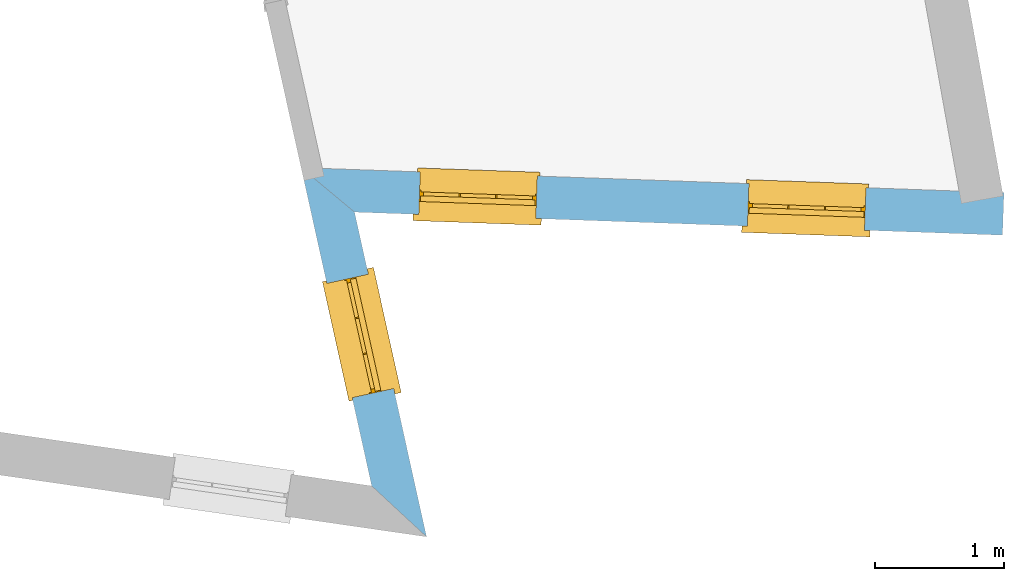
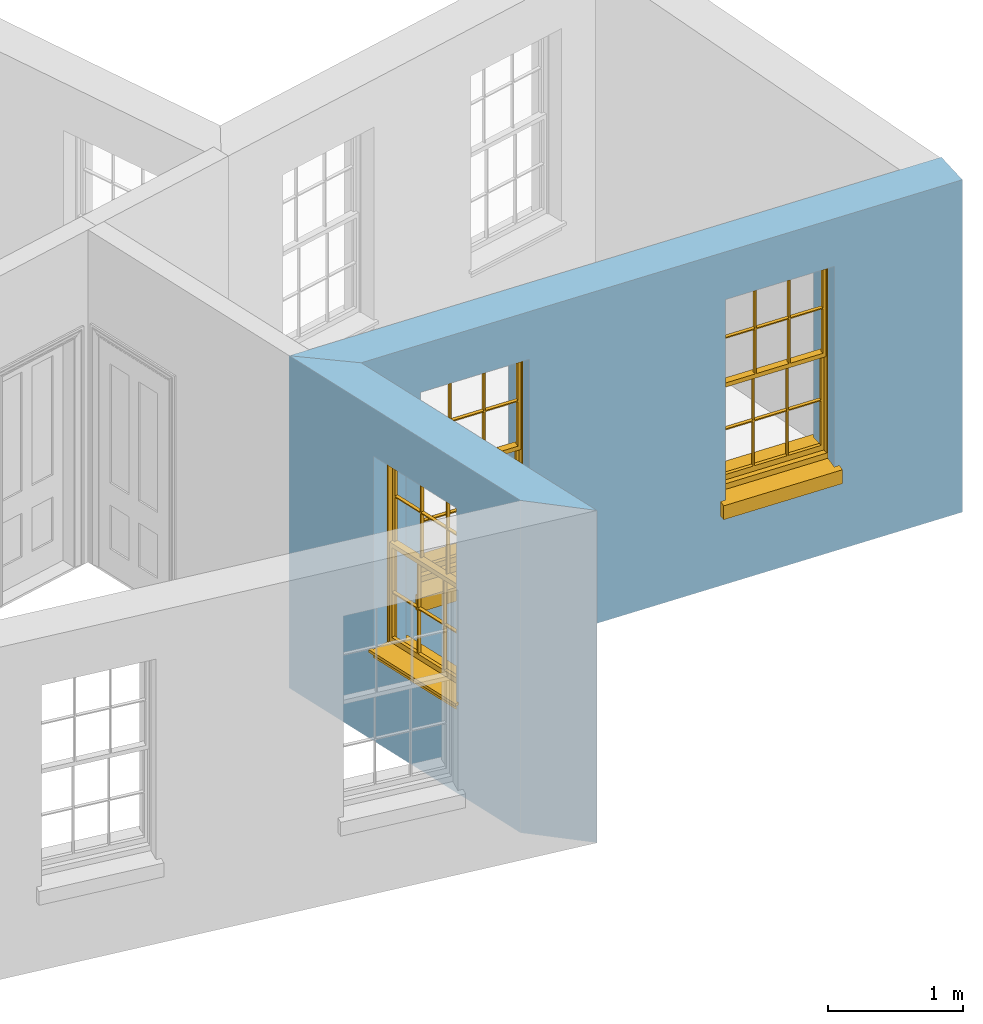
# One storey, part 6 of 10: 3 windows, 3 openings, plus 2 elements that do not belong to this part.
"""IFC2X3 building model written with IfcOpenShell, lengths in metres."""

from ifc_helpers import new_model, si_unit, frame, origin, place, context, subcontext, project, spatial, polyline, outline, extrude, faceted_brep, material, layer, layer_set, layer_usage, element, fill, save


model = new_model("IFC2X3")

# Units and contexts
model_context = context("Model", 3, world=origin())
body_context = subcontext(model_context, "Body", "Model", "MODEL_VIEW")
ifc_project = project(units=[si_unit("PLANEANGLEUNIT", "RADIAN"), si_unit("MASSUNIT", "GRAM", prefix="KILO"), si_unit("FORCEUNIT", "NEWTON", prefix="KILO"), si_unit("LENGTHUNIT", "METRE")], contexts=[model_context])

# Site, building, storey
site_placement = place(None, origin())
site = spatial("IfcSite", under=ifc_project, at=site_placement, CompositionType="ELEMENT")
building_placement = place(None, origin())
building = spatial("IfcBuilding", under=site, at=building_placement, Name="Building plot-16", CompositionType="ELEMENT")
storey_placement = place(None, frame((0.0, 0.0, 6.0)))
storey = spatial("IfcBuildingStorey", under=building, at=storey_placement, Name="Floor 1", CompositionType="ELEMENT", Elevation=6.0)

# Wall, opening, window
ifc_material = material(Name="Masonry")
ifc_layer = layer(ifc_material, 0.33, ventilated=False)
ifc_layer_set = layer_set([ifc_layer], Name="My Wall")
ifc_layer_usage = layer_usage(ifc_layer_set, "AXIS2", "NEGATIVE", 0.08)
wall_1_placement = place(storey_placement, origin())
wall_1 = element("IfcWallStandardCase", 1, at=wall_1_placement, inside=storey, material=ifc_layer_usage, Name="exterior", context=body_context, shape_type="SweptSolid", body=[
    extrude(outline(polyline([(97.1549084446968, 30.7413476988825), (97.5805288405461, 30.3463147311604), (97.0216212073761, 32.8666175367297), (96.607105896403, 33.2115739356083), (97.1549084446968, 30.7413476988825)])), origin(), (0.0, 0.0, 1.0), 3.0),
])
opening_1_placement = place(storey_placement, frame((0.0, 0.0, 0.75)))
opening_1 = element("IfcOpeningElement", 2, at=opening_1_placement, cuts=wall_1, Name="Opening", ObjectType="Opening", context=body_context, shape_type="SweptSolid", body=[
    extrude(outline(polyline([(97.3254209005413, 31.496682374684), (97.1284037496912, 32.3850990799923), (96.8062306587552, 32.3136533000138), (97.0032478096053, 31.4252365947054), (97.3254209005413, 31.496682374684)])), origin(), (0.0, 0.0, 1.0), 1.82),
])
window_1_placement = place(storey_placement, frame((97.0813503771049, 31.4425567837911, 0.75), z_axis=(0.0, 0.0, 1.0), x_axis=(-0.197017150850044, 0.888416705308341, 0.0)))
window_1 = element("IfcWindow", 3, at=window_1_placement, inside=storey, Name="circulation outside window", OverallHeight=1.82, OverallWidth=0.91, context=body_context, shape_type="Brep", held_by="IfcProductRepresentation", body=[
    faceted_brep([(0.033125, -0.105, 0.975209), (0.01, -0.105, 0.975209), (0.033125, -0.105, 1.376042), (0.876875, -0.105, 0.975209), (0.876875, -0.105, 1.376042), (0.9, -0.105, 0.975209), (0.876875, -0.105, 1.386042), (0.876875, -0.105, 1.786875), (0.9, -0.105, 1.81), (0.033125, -0.105, 1.786875), (0.033125, -0.105, 1.386042), (0.01, -0.105, 1.81), (0.876875, -0.135, 1.376042), (0.876875, -0.135, 0.975209), (0.9, -0.135, 0.937083), (0.033125, -0.135, 1.786875), (0.01, -0.135, 1.81), (0.033125, -0.135, 1.386042), (0.01, -0.135, 0.937083), (0.033125, -0.135, 0.975209), (0.033125, -0.135, 1.376042), (0.876875, -0.135, 1.786875), (0.876875, -0.135, 1.386042), (0.9, -0.135, 1.81), (0.033125, -0.105, 0.937083), (0.01, -0.105, 0.937083), (0.033125, -0.105, 0.53625), (0.876875, -0.105, 0.937083), (0.876875, -0.105, 0.53625), (0.9, -0.105, 0.937083), (0.876875, -0.105, 0.52625), (0.876875, -0.105, 0.125417), (0.9, -0.105, 0.077167), (0.033125, -0.105, 0.125417), (0.033125, -0.105, 0.52625), (0.01, -0.105, 0.077167), (-0.0425, -0.25, 0.01), (-0.0425, -0.3, 0.001667), (0.0, -0.25, 0.01), (0.9525, -0.25, 0.01), (0.91, -0.25, 0.01), (0.9525, -0.3, 0.001667), (-0.02, 0.08, 0.077167), (0.0, 0.08, 0.077167), (-0.02, 0.11, 0.077167), (0.0, -0.06, 0.077167), (0.01, -0.06, 0.077167), (0.91, -0.06, 0.077167), (0.91, 0.08, 0.077167), (0.9, -0.06, 0.077167), (0.93, 0.08, 0.077167), (0.93, 0.11, 0.077167), (0.01, -0.075, 0.975209), (0.9, -0.075, 0.975209), (0.876875, -0.075, 0.125417), (0.876875, -0.075, 0.52625), (0.9, -0.075, 0.077167), (0.876875, -0.075, 0.53625), (0.876875, -0.075, 0.937083), (0.033125, -0.075, 0.125417), (0.01, -0.075, 0.077167), (0.033125, -0.075, 0.52625), (0.033125, -0.075, 0.937083), (0.033125, -0.075, 0.53625), (-0.02, 0.08, 0.052167), (-0.02, 0.11, 0.052167), (0.93, 0.11, 0.052167), (0.93, 0.08, 0.052167), (0.91, 0.08, 0.052167), (0.0, 0.08, 0.052167), (0.91, -0.15, 0.026667), (0.0, -0.15, 0.026667), (-0.0425, -0.3, -0.123333), (0.9525, -0.3, -0.123333), (-0.0425, -0.25, -0.123333), (0.9525, -0.25, -0.123333), (0.01, -0.06, 1.81), (0.9, -0.06, 1.81), (0.0, -0.06, 1.82), (0.91, -0.06, 1.82), (0.01, -0.15, 0.077167), (0.9, -0.15, 0.077167), (0.592292, -0.105, 0.125417), (0.592292, -0.075, 0.125417), (0.317708, -0.075, 0.125417), (0.317708, -0.105, 0.125417), (0.592292, -0.105, 0.53625), (0.317708, -0.105, 0.53625), (0.317708, -0.105, 0.52625), (0.592292, -0.105, 0.52625), (0.592292, -0.075, 0.53625), (0.317708, -0.075, 0.53625), (0.592292, -0.135, 1.386042), (0.592292, -0.105, 1.386042), (0.317708, -0.105, 1.386042), (0.317708, -0.135, 1.386042), (0.317708, -0.135, 1.376042), (0.592292, -0.135, 1.376042), (0.317708, -0.105, 1.376042), (0.592292, -0.105, 1.376042), (0.602292, -0.135, 1.376042), (0.592292, -0.135, 0.975209), (0.602292, -0.135, 0.975209), (0.602292, -0.105, 0.975209), (0.592292, -0.105, 0.975209), (0.602292, -0.105, 1.376042), (0.602292, -0.075, 0.53625), (0.602292, -0.105, 0.53625), (0.317708, -0.075, 0.52625), (0.307708, -0.075, 0.125417), (0.307708, -0.075, 0.52625), (0.602292, -0.075, 0.52625), (0.602292, -0.075, 0.125417), (0.592292, -0.075, 0.52625), (0.307708, -0.075, 0.53625), (0.317708, -0.075, 0.937083), (0.307708, -0.075, 0.937083), (0.602292, -0.075, 0.937083), (0.592292, -0.075, 0.937083), (0.307708, -0.105, 0.52625), (0.307708, -0.105, 0.125417), (0.307708, -0.105, 0.53625), (0.307708, -0.105, 0.937083), (0.592292, -0.105, 0.937083), (0.317708, -0.105, 0.937083), (0.602292, -0.105, 0.937083), (0.602292, -0.105, 0.52625), (0.602292, -0.105, 0.125417), (0.307708, -0.135, 1.386042), (0.307708, -0.135, 1.376042), (0.307708, -0.135, 0.975209), (0.317708, -0.135, 0.975209), (0.317708, -0.135, 1.786875), (0.307708, -0.135, 1.786875), (0.602292, -0.135, 1.786875), (0.592292, -0.135, 1.786875), (0.602292, -0.135, 1.386042), (0.602292, -0.105, 1.386042), (0.307708, -0.105, 1.386042), (0.307708, -0.105, 1.786875), (0.317708, -0.105, 1.786875), (0.592292, -0.105, 1.786875), (0.602292, -0.105, 1.786875), (0.307708, -0.105, 1.376042), (0.317708, -0.105, 0.975209), (0.307708, -0.105, 0.975209), (0.91, -0.15, 1.82), (0.9, -0.15, 1.81), (0.01, -0.15, 1.81), (0.0, -0.15, 1.82), (0.91, -0.25, 0.0), (0.0, -0.25, 0.0), (0.91, 0.08, 0.0), (0.0, 0.08, 0.0)], [[[0, 1, 2]], [[3, 4, 5]], [[6, 7, 8]], [[9, 10, 11]], [[12, 13, 14]], [[15, 16, 17]], [[18, 19, 20]], [[21, 22, 23]], [[24, 25, 26]], [[27, 28, 29]], [[30, 31, 32]], [[33, 34, 35]], [[14, 27, 29]], [[25, 24, 18]], [[36, 37, 38]], [[39, 40, 41]], [[42, 43, 44]], [[45, 46, 43]], [[47, 48, 49]], [[50, 51, 48]], [[1, 0, 52]], [[5, 53, 3]], [[54, 55, 56]], [[57, 58, 53]], [[59, 60, 61]], [[62, 63, 52]], [[48, 43, 46, 49]], [[51, 44, 43, 48]], [[64, 42, 44, 65]], [[65, 44, 51, 66]], [[66, 51, 50, 67]], [[65, 66, 68, 69]], [[60, 56, 49, 46]], [[70, 71, 38, 40]], [[37, 41, 40, 38]], [[37, 72, 73, 41]], [[74, 75, 73, 72]], [[8, 11, 76, 77]], [[76, 78, 79, 77]], [[32, 35, 80, 81]], [[81, 80, 71, 70]], [[82, 83, 84, 85]], [[86, 87, 88, 89]], [[86, 90, 91, 87]], [[92, 93, 94, 95]], [[92, 95, 96, 97]], [[96, 98, 99, 97]], [[100, 97, 101, 102]], [[103, 104, 99, 105]], [[97, 99, 104, 101]], [[102, 103, 105, 100]], [[28, 57, 106, 107]], [[108, 84, 109, 110]], [[111, 112, 83, 113]], [[114, 110, 61, 63]], [[90, 113, 108, 91]], [[115, 91, 114, 116]], [[117, 106, 90, 118]], [[111, 106, 57, 55]], [[119, 110, 109, 120]], [[34, 61, 110, 119]], [[89, 113, 83, 82]], [[88, 108, 113, 89]], [[85, 84, 108, 88]], [[121, 114, 63, 26]], [[122, 116, 114, 121]], [[123, 118, 90, 86]], [[87, 91, 115, 124]], [[107, 106, 117, 125]], [[126, 111, 55, 30]], [[127, 112, 111, 126]], [[126, 30, 28, 107]], [[88, 119, 120, 85]], [[126, 89, 82, 127]], [[125, 123, 86, 107]], [[121, 26, 34, 119]], [[124, 122, 121, 87]], [[128, 17, 20, 129]], [[96, 129, 130, 131]], [[132, 133, 128, 95]], [[134, 135, 92, 136]], [[100, 12, 22, 136]], [[137, 6, 4, 105]], [[94, 138, 139, 140]], [[137, 93, 141, 142]], [[99, 98, 94, 93]], [[143, 2, 10, 138]], [[144, 145, 143, 98]], [[129, 143, 145, 130]], [[20, 2, 143, 129]], [[131, 144, 98, 96]], [[128, 138, 10, 17]], [[133, 139, 138, 128]], [[135, 141, 93, 92]], [[95, 94, 140, 132]], [[22, 6, 137, 136]], [[136, 137, 142, 134]], [[100, 105, 4, 12]], [[107, 86, 89, 126]], [[106, 111, 113, 90]], [[91, 108, 110, 114]], [[87, 121, 119, 88]], [[97, 100, 136, 92]], [[129, 96, 95, 128]], [[98, 143, 138, 94]], [[105, 99, 93, 137]], [[131, 101, 104, 144]], [[124, 115, 118, 123]], [[132, 140, 141, 135]], [[120, 109, 59, 33]], [[15, 9, 139, 133]], [[134, 142, 7, 21]], [[31, 54, 112, 127]], [[36, 74, 72, 37]], [[39, 41, 73, 75]], [[18, 14, 101, 131]], [[23, 16, 132, 135]], [[83, 56, 60, 84]], [[52, 53, 118, 115]], [[53, 52, 144, 104]], [[11, 8, 141, 140]], [[14, 18, 124, 123]], [[2, 1, 11, 10]], [[8, 5, 4, 6]], [[57, 53, 56, 55]], [[60, 52, 63, 61]], [[26, 25, 35, 34]], [[32, 29, 28, 30]], [[14, 23, 22, 12]], [[18, 20, 17, 16]], [[19, 0, 2, 20]], [[17, 10, 9, 15]], [[12, 4, 3, 13]], [[21, 7, 6, 22]], [[27, 58, 57, 28]], [[30, 55, 54, 31]], [[33, 59, 61, 34]], [[26, 63, 62, 24]], [[5, 8, 77, 53]], [[76, 11, 1, 52]], [[46, 45, 78, 76]], [[49, 77, 79, 47]], [[70, 146, 147, 81]], [[71, 80, 148, 149]], [[19, 130, 145, 0]], [[102, 13, 3, 103]], [[116, 122, 24, 62]], [[29, 32, 81, 14]], [[80, 35, 25, 18]], [[60, 46, 76, 52]], [[77, 49, 56, 53]], [[23, 14, 81, 147]], [[16, 148, 80, 18]], [[35, 85, 120]], [[120, 33, 35]], [[127, 82, 32]], [[32, 31, 127]], [[32, 82, 85, 35]], [[102, 101, 14]], [[14, 13, 102]], [[18, 131, 130]], [[130, 19, 18]], [[134, 21, 23]], [[23, 135, 134]], [[16, 15, 133]], [[133, 132, 16]], [[11, 140, 139]], [[139, 9, 11]], [[142, 141, 8]], [[8, 7, 142]], [[23, 147, 148, 16]], [[146, 149, 148, 147]], [[52, 115, 116]], [[116, 62, 52]], [[118, 53, 117]], [[58, 117, 53]], [[27, 125, 117, 58]], [[56, 83, 112]], [[112, 54, 56]], [[109, 84, 60]], [[60, 59, 109]], [[125, 27, 14]], [[14, 123, 125]], [[122, 124, 18]], [[18, 24, 122]], [[145, 144, 52]], [[52, 0, 145]], [[103, 3, 53]], [[53, 104, 103]], [[79, 78, 149, 146]], [[78, 45, 71, 149]], [[146, 70, 47, 79]], [[150, 75, 74, 151]], [[68, 66, 67]], [[48, 68, 67, 50]], [[69, 64, 65]], [[42, 64, 69, 43]], [[69, 68, 152, 153]], [[70, 68, 48, 47]], [[150, 152, 68, 70]], [[43, 69, 71, 45]], [[69, 153, 151, 71]], [[152, 150, 151, 153]], [[38, 151, 74, 36]], [[71, 151, 38]], [[39, 75, 150, 40]], [[40, 150, 70]]]),
])
fill(opening_1, window_1)

# Wall, openings, windows
wall_2_placement = place(storey_placement, origin())
wall_2 = element("IfcWallStandardCase", 4, at=wall_2_placement, inside=storey, material=ifc_layer_usage, Name="exterior", context=body_context, shape_type="SweptSolid", body=[
    extrude(outline(polyline([(96.607105896403, 33.2115739356083), (97.0216212073761, 32.8666175367297), (102.050747108567, 32.6876914939727), (102.06248041193, 33.0174828364791), (96.607105896403, 33.2115739356083)])), origin(), (0.0, 0.0, 1.0), 3.0),
])
opening_2_placement = place(storey_placement, frame((0.0, 0.0, 0.75)))
opening_2 = element("IfcOpeningElement", 5, at=opening_2_placement, cuts=wall_2, Name="Opening", ObjectType="Opening", context=body_context, shape_type="SweptSolid", body=[
    extrude(outline(polyline([(97.5195431828704, 32.8489024883441), (98.4289677940245, 32.8165470154335), (98.4407010973877, 33.14633835794), (97.5312764862336, 33.1786938308505), (97.5195431828704, 32.8489024883441)])), origin(), (0.0, 0.0, 1.0), 1.82),
])
opening_3_placement = place(storey_placement, frame((0.0, 0.0, 0.75)))
opening_3 = element("IfcOpeningElement", 6, at=opening_3_placement, cuts=wall_2, Name="Opening", ObjectType="Opening", context=body_context, shape_type="SweptSolid", body=[
    extrude(outline(polyline([(100.070642978856, 32.7581395605228), (100.98006759001, 32.7257840876123), (100.991800893373, 33.0555754301187), (100.082376282219, 33.0879309030292), (100.070642978856, 32.7581395605228)])), origin(), (0.0, 0.0, 1.0), 1.82),
])
window_2_placement = place(storey_placement, frame((97.5284320490546, 33.0987444144853, 0.75), z_axis=(0.0, 0.0, 1.0), x_axis=(0.909424611154066, -0.0323554729105382, 0.0)))
window_2 = element("IfcWindow", 7, at=window_2_placement, inside=storey, Name="bedroom outside window", OverallHeight=1.82, OverallWidth=0.91, context=body_context, shape_type="Brep", held_by="IfcProductRepresentation", body=[
    faceted_brep([(0.033125, -0.105, 0.975209), (0.01, -0.105, 0.975209), (0.033125, -0.105, 1.376042), (0.876875, -0.105, 0.975209), (0.876875, -0.105, 1.376042), (0.9, -0.105, 0.975209), (0.876875, -0.105, 1.386042), (0.876875, -0.105, 1.786875), (0.9, -0.105, 1.81), (0.033125, -0.105, 1.786875), (0.033125, -0.105, 1.386042), (0.01, -0.105, 1.81), (0.876875, -0.135, 1.376042), (0.876875, -0.135, 0.975209), (0.9, -0.135, 0.937083), (0.033125, -0.135, 1.786875), (0.01, -0.135, 1.81), (0.033125, -0.135, 1.386042), (0.01, -0.135, 0.937083), (0.033125, -0.135, 0.975209), (0.033125, -0.135, 1.376042), (0.876875, -0.135, 1.786875), (0.876875, -0.135, 1.386042), (0.9, -0.135, 1.81), (0.033125, -0.105, 0.937083), (0.01, -0.105, 0.937083), (0.033125, -0.105, 0.53625), (0.876875, -0.105, 0.937083), (0.876875, -0.105, 0.53625), (0.9, -0.105, 0.937083), (0.876875, -0.105, 0.52625), (0.876875, -0.105, 0.125417), (0.9, -0.105, 0.077167), (0.033125, -0.105, 0.125417), (0.033125, -0.105, 0.52625), (0.01, -0.105, 0.077167), (-0.0425, -0.25, 0.01), (-0.0425, -0.3, 0.001667), (0.0, -0.25, 0.01), (0.9525, -0.25, 0.01), (0.91, -0.25, 0.01), (0.9525, -0.3, 0.001667), (-0.02, 0.08, 0.077167), (0.0, 0.08, 0.077167), (-0.02, 0.11, 0.077167), (0.0, -0.06, 0.077167), (0.01, -0.06, 0.077167), (0.91, -0.06, 0.077167), (0.91, 0.08, 0.077167), (0.9, -0.06, 0.077167), (0.93, 0.08, 0.077167), (0.93, 0.11, 0.077167), (0.01, -0.075, 0.975209), (0.9, -0.075, 0.975209), (0.876875, -0.075, 0.125417), (0.876875, -0.075, 0.52625), (0.9, -0.075, 0.077167), (0.876875, -0.075, 0.53625), (0.876875, -0.075, 0.937083), (0.033125, -0.075, 0.125417), (0.01, -0.075, 0.077167), (0.033125, -0.075, 0.52625), (0.033125, -0.075, 0.937083), (0.033125, -0.075, 0.53625), (-0.02, 0.08, 0.052167), (-0.02, 0.11, 0.052167), (0.93, 0.11, 0.052167), (0.93, 0.08, 0.052167), (0.91, 0.08, 0.052167), (0.0, 0.08, 0.052167), (0.91, -0.15, 0.026667), (0.0, -0.15, 0.026667), (-0.0425, -0.3, -0.123333), (0.9525, -0.3, -0.123333), (-0.0425, -0.25, -0.123333), (0.9525, -0.25, -0.123333), (0.01, -0.06, 1.81), (0.9, -0.06, 1.81), (0.0, -0.06, 1.82), (0.91, -0.06, 1.82), (0.01, -0.15, 0.077167), (0.9, -0.15, 0.077167), (0.592292, -0.105, 0.125417), (0.592292, -0.075, 0.125417), (0.317708, -0.075, 0.125417), (0.317708, -0.105, 0.125417), (0.592292, -0.105, 0.53625), (0.317708, -0.105, 0.53625), (0.317708, -0.105, 0.52625), (0.592292, -0.105, 0.52625), (0.592292, -0.075, 0.53625), (0.317708, -0.075, 0.53625), (0.592292, -0.135, 1.386042), (0.592292, -0.105, 1.386042), (0.317708, -0.105, 1.386042), (0.317708, -0.135, 1.386042), (0.317708, -0.135, 1.376042), (0.592292, -0.135, 1.376042), (0.317708, -0.105, 1.376042), (0.592292, -0.105, 1.376042), (0.602292, -0.135, 1.376042), (0.592292, -0.135, 0.975209), (0.602292, -0.135, 0.975209), (0.602292, -0.105, 0.975209), (0.592292, -0.105, 0.975209), (0.602292, -0.105, 1.376042), (0.602292, -0.075, 0.53625), (0.602292, -0.105, 0.53625), (0.317708, -0.075, 0.52625), (0.307708, -0.075, 0.125417), (0.307708, -0.075, 0.52625), (0.602292, -0.075, 0.52625), (0.602292, -0.075, 0.125417), (0.592292, -0.075, 0.52625), (0.307708, -0.075, 0.53625), (0.317708, -0.075, 0.937083), (0.307708, -0.075, 0.937083), (0.602292, -0.075, 0.937083), (0.592292, -0.075, 0.937083), (0.307708, -0.105, 0.52625), (0.307708, -0.105, 0.125417), (0.307708, -0.105, 0.53625), (0.307708, -0.105, 0.937083), (0.592292, -0.105, 0.937083), (0.317708, -0.105, 0.937083), (0.602292, -0.105, 0.937083), (0.602292, -0.105, 0.52625), (0.602292, -0.105, 0.125417), (0.307708, -0.135, 1.386042), (0.307708, -0.135, 1.376042), (0.307708, -0.135, 0.975209), (0.317708, -0.135, 0.975209), (0.317708, -0.135, 1.786875), (0.307708, -0.135, 1.786875), (0.602292, -0.135, 1.786875), (0.592292, -0.135, 1.786875), (0.602292, -0.135, 1.386042), (0.602292, -0.105, 1.386042), (0.307708, -0.105, 1.386042), (0.307708, -0.105, 1.786875), (0.317708, -0.105, 1.786875), (0.592292, -0.105, 1.786875), (0.602292, -0.105, 1.786875), (0.307708, -0.105, 1.376042), (0.317708, -0.105, 0.975209), (0.307708, -0.105, 0.975209), (0.91, -0.15, 1.82), (0.9, -0.15, 1.81), (0.01, -0.15, 1.81), (0.0, -0.15, 1.82), (0.91, -0.25, 0.0), (0.0, -0.25, 0.0), (0.91, 0.08, 0.0), (0.0, 0.08, 0.0)], [[[0, 1, 2]], [[3, 4, 5]], [[6, 7, 8]], [[9, 10, 11]], [[12, 13, 14]], [[15, 16, 17]], [[18, 19, 20]], [[21, 22, 23]], [[24, 25, 26]], [[27, 28, 29]], [[30, 31, 32]], [[33, 34, 35]], [[14, 27, 29]], [[25, 24, 18]], [[36, 37, 38]], [[39, 40, 41]], [[42, 43, 44]], [[45, 46, 43]], [[47, 48, 49]], [[50, 51, 48]], [[1, 0, 52]], [[5, 53, 3]], [[54, 55, 56]], [[57, 58, 53]], [[59, 60, 61]], [[62, 63, 52]], [[48, 43, 46, 49]], [[51, 44, 43, 48]], [[64, 42, 44, 65]], [[65, 44, 51, 66]], [[66, 51, 50, 67]], [[65, 66, 68, 69]], [[60, 56, 49, 46]], [[70, 71, 38, 40]], [[37, 41, 40, 38]], [[37, 72, 73, 41]], [[74, 75, 73, 72]], [[8, 11, 76, 77]], [[76, 78, 79, 77]], [[32, 35, 80, 81]], [[81, 80, 71, 70]], [[82, 83, 84, 85]], [[86, 87, 88, 89]], [[86, 90, 91, 87]], [[92, 93, 94, 95]], [[92, 95, 96, 97]], [[96, 98, 99, 97]], [[100, 97, 101, 102]], [[103, 104, 99, 105]], [[97, 99, 104, 101]], [[102, 103, 105, 100]], [[28, 57, 106, 107]], [[108, 84, 109, 110]], [[111, 112, 83, 113]], [[114, 110, 61, 63]], [[90, 113, 108, 91]], [[115, 91, 114, 116]], [[117, 106, 90, 118]], [[111, 106, 57, 55]], [[119, 110, 109, 120]], [[34, 61, 110, 119]], [[89, 113, 83, 82]], [[88, 108, 113, 89]], [[85, 84, 108, 88]], [[121, 114, 63, 26]], [[122, 116, 114, 121]], [[123, 118, 90, 86]], [[87, 91, 115, 124]], [[107, 106, 117, 125]], [[126, 111, 55, 30]], [[127, 112, 111, 126]], [[126, 30, 28, 107]], [[88, 119, 120, 85]], [[126, 89, 82, 127]], [[125, 123, 86, 107]], [[121, 26, 34, 119]], [[124, 122, 121, 87]], [[128, 17, 20, 129]], [[96, 129, 130, 131]], [[132, 133, 128, 95]], [[134, 135, 92, 136]], [[100, 12, 22, 136]], [[137, 6, 4, 105]], [[94, 138, 139, 140]], [[137, 93, 141, 142]], [[99, 98, 94, 93]], [[143, 2, 10, 138]], [[144, 145, 143, 98]], [[129, 143, 145, 130]], [[20, 2, 143, 129]], [[131, 144, 98, 96]], [[128, 138, 10, 17]], [[133, 139, 138, 128]], [[135, 141, 93, 92]], [[95, 94, 140, 132]], [[22, 6, 137, 136]], [[136, 137, 142, 134]], [[100, 105, 4, 12]], [[107, 86, 89, 126]], [[106, 111, 113, 90]], [[91, 108, 110, 114]], [[87, 121, 119, 88]], [[97, 100, 136, 92]], [[129, 96, 95, 128]], [[98, 143, 138, 94]], [[105, 99, 93, 137]], [[131, 101, 104, 144]], [[124, 115, 118, 123]], [[132, 140, 141, 135]], [[120, 109, 59, 33]], [[15, 9, 139, 133]], [[134, 142, 7, 21]], [[31, 54, 112, 127]], [[36, 74, 72, 37]], [[39, 41, 73, 75]], [[18, 14, 101, 131]], [[23, 16, 132, 135]], [[83, 56, 60, 84]], [[52, 53, 118, 115]], [[53, 52, 144, 104]], [[11, 8, 141, 140]], [[14, 18, 124, 123]], [[2, 1, 11, 10]], [[8, 5, 4, 6]], [[57, 53, 56, 55]], [[60, 52, 63, 61]], [[26, 25, 35, 34]], [[32, 29, 28, 30]], [[14, 23, 22, 12]], [[18, 20, 17, 16]], [[19, 0, 2, 20]], [[17, 10, 9, 15]], [[12, 4, 3, 13]], [[21, 7, 6, 22]], [[27, 58, 57, 28]], [[30, 55, 54, 31]], [[33, 59, 61, 34]], [[26, 63, 62, 24]], [[5, 8, 77, 53]], [[76, 11, 1, 52]], [[46, 45, 78, 76]], [[49, 77, 79, 47]], [[70, 146, 147, 81]], [[71, 80, 148, 149]], [[19, 130, 145, 0]], [[102, 13, 3, 103]], [[116, 122, 24, 62]], [[29, 32, 81, 14]], [[80, 35, 25, 18]], [[60, 46, 76, 52]], [[77, 49, 56, 53]], [[23, 14, 81, 147]], [[16, 148, 80, 18]], [[35, 85, 120]], [[120, 33, 35]], [[127, 82, 32]], [[32, 31, 127]], [[32, 82, 85, 35]], [[102, 101, 14]], [[14, 13, 102]], [[18, 131, 130]], [[130, 19, 18]], [[134, 21, 23]], [[23, 135, 134]], [[16, 15, 133]], [[133, 132, 16]], [[11, 140, 139]], [[139, 9, 11]], [[142, 141, 8]], [[8, 7, 142]], [[23, 147, 148, 16]], [[146, 149, 148, 147]], [[52, 115, 116]], [[116, 62, 52]], [[118, 53, 117]], [[58, 117, 53]], [[27, 125, 117, 58]], [[56, 83, 112]], [[112, 54, 56]], [[109, 84, 60]], [[60, 59, 109]], [[125, 27, 14]], [[14, 123, 125]], [[122, 124, 18]], [[18, 24, 122]], [[145, 144, 52]], [[52, 0, 145]], [[103, 3, 53]], [[53, 104, 103]], [[79, 78, 149, 146]], [[78, 45, 71, 149]], [[146, 70, 47, 79]], [[150, 75, 74, 151]], [[68, 66, 67]], [[48, 68, 67, 50]], [[69, 64, 65]], [[42, 64, 69, 43]], [[69, 68, 152, 153]], [[70, 68, 48, 47]], [[150, 152, 68, 70]], [[43, 69, 71, 45]], [[69, 153, 151, 71]], [[152, 150, 151, 153]], [[38, 151, 74, 36]], [[71, 151, 38]], [[39, 75, 150, 40]], [[40, 150, 70]]]),
])
fill(opening_2, window_2)
window_3_placement = place(storey_placement, frame((100.07953184504, 33.007981486664, 0.75), z_axis=(0.0, 0.0, 1.0), x_axis=(0.909424611154066, -0.0323554729105382, 0.0)))
window_3 = element("IfcWindow", 8, at=window_3_placement, inside=storey, Name="bedroom outside window", OverallHeight=1.82, OverallWidth=0.91, context=body_context, shape_type="Brep", held_by="IfcProductRepresentation", body=[
    faceted_brep([(0.033125, -0.105, 0.975209), (0.01, -0.105, 0.975209), (0.033125, -0.105, 1.376042), (0.876875, -0.105, 0.975209), (0.876875, -0.105, 1.376042), (0.9, -0.105, 0.975209), (0.876875, -0.105, 1.386042), (0.876875, -0.105, 1.786875), (0.9, -0.105, 1.81), (0.033125, -0.105, 1.786875), (0.033125, -0.105, 1.386042), (0.01, -0.105, 1.81), (0.876875, -0.135, 1.376042), (0.876875, -0.135, 0.975209), (0.9, -0.135, 0.937083), (0.033125, -0.135, 1.786875), (0.01, -0.135, 1.81), (0.033125, -0.135, 1.386042), (0.01, -0.135, 0.937083), (0.033125, -0.135, 0.975209), (0.033125, -0.135, 1.376042), (0.876875, -0.135, 1.786875), (0.876875, -0.135, 1.386042), (0.9, -0.135, 1.81), (0.033125, -0.105, 0.937083), (0.01, -0.105, 0.937083), (0.033125, -0.105, 0.53625), (0.876875, -0.105, 0.937083), (0.876875, -0.105, 0.53625), (0.9, -0.105, 0.937083), (0.876875, -0.105, 0.52625), (0.876875, -0.105, 0.125417), (0.9, -0.105, 0.077167), (0.033125, -0.105, 0.125417), (0.033125, -0.105, 0.52625), (0.01, -0.105, 0.077167), (-0.0425, -0.25, 0.01), (-0.0425, -0.3, 0.001667), (0.0, -0.25, 0.01), (0.9525, -0.25, 0.01), (0.91, -0.25, 0.01), (0.9525, -0.3, 0.001667), (-0.02, 0.08, 0.077167), (0.0, 0.08, 0.077167), (-0.02, 0.11, 0.077167), (0.0, -0.06, 0.077167), (0.01, -0.06, 0.077167), (0.91, -0.06, 0.077167), (0.91, 0.08, 0.077167), (0.9, -0.06, 0.077167), (0.93, 0.08, 0.077167), (0.93, 0.11, 0.077167), (0.01, -0.075, 0.975209), (0.9, -0.075, 0.975209), (0.876875, -0.075, 0.125417), (0.876875, -0.075, 0.52625), (0.9, -0.075, 0.077167), (0.876875, -0.075, 0.53625), (0.876875, -0.075, 0.937083), (0.033125, -0.075, 0.125417), (0.01, -0.075, 0.077167), (0.033125, -0.075, 0.52625), (0.033125, -0.075, 0.937083), (0.033125, -0.075, 0.53625), (-0.02, 0.08, 0.052167), (-0.02, 0.11, 0.052167), (0.93, 0.11, 0.052167), (0.93, 0.08, 0.052167), (0.91, 0.08, 0.052167), (0.0, 0.08, 0.052167), (0.91, -0.15, 0.026667), (0.0, -0.15, 0.026667), (-0.0425, -0.3, -0.123333), (0.9525, -0.3, -0.123333), (-0.0425, -0.25, -0.123333), (0.9525, -0.25, -0.123333), (0.01, -0.06, 1.81), (0.9, -0.06, 1.81), (0.0, -0.06, 1.82), (0.91, -0.06, 1.82), (0.01, -0.15, 0.077167), (0.9, -0.15, 0.077167), (0.592292, -0.105, 0.125417), (0.592292, -0.075, 0.125417), (0.317708, -0.075, 0.125417), (0.317708, -0.105, 0.125417), (0.592292, -0.105, 0.53625), (0.317708, -0.105, 0.53625), (0.317708, -0.105, 0.52625), (0.592292, -0.105, 0.52625), (0.592292, -0.075, 0.53625), (0.317708, -0.075, 0.53625), (0.592292, -0.135, 1.386042), (0.592292, -0.105, 1.386042), (0.317708, -0.105, 1.386042), (0.317708, -0.135, 1.386042), (0.317708, -0.135, 1.376042), (0.592292, -0.135, 1.376042), (0.317708, -0.105, 1.376042), (0.592292, -0.105, 1.376042), (0.602292, -0.135, 1.376042), (0.592292, -0.135, 0.975209), (0.602292, -0.135, 0.975209), (0.602292, -0.105, 0.975209), (0.592292, -0.105, 0.975209), (0.602292, -0.105, 1.376042), (0.602292, -0.075, 0.53625), (0.602292, -0.105, 0.53625), (0.317708, -0.075, 0.52625), (0.307708, -0.075, 0.125417), (0.307708, -0.075, 0.52625), (0.602292, -0.075, 0.52625), (0.602292, -0.075, 0.125417), (0.592292, -0.075, 0.52625), (0.307708, -0.075, 0.53625), (0.317708, -0.075, 0.937083), (0.307708, -0.075, 0.937083), (0.602292, -0.075, 0.937083), (0.592292, -0.075, 0.937083), (0.307708, -0.105, 0.52625), (0.307708, -0.105, 0.125417), (0.307708, -0.105, 0.53625), (0.307708, -0.105, 0.937083), (0.592292, -0.105, 0.937083), (0.317708, -0.105, 0.937083), (0.602292, -0.105, 0.937083), (0.602292, -0.105, 0.52625), (0.602292, -0.105, 0.125417), (0.307708, -0.135, 1.386042), (0.307708, -0.135, 1.376042), (0.307708, -0.135, 0.975209), (0.317708, -0.135, 0.975209), (0.317708, -0.135, 1.786875), (0.307708, -0.135, 1.786875), (0.602292, -0.135, 1.786875), (0.592292, -0.135, 1.786875), (0.602292, -0.135, 1.386042), (0.602292, -0.105, 1.386042), (0.307708, -0.105, 1.386042), (0.307708, -0.105, 1.786875), (0.317708, -0.105, 1.786875), (0.592292, -0.105, 1.786875), (0.602292, -0.105, 1.786875), (0.307708, -0.105, 1.376042), (0.317708, -0.105, 0.975209), (0.307708, -0.105, 0.975209), (0.91, -0.15, 1.82), (0.9, -0.15, 1.81), (0.01, -0.15, 1.81), (0.0, -0.15, 1.82), (0.91, -0.25, 0.0), (0.0, -0.25, 0.0), (0.91, 0.08, 0.0), (0.0, 0.08, 0.0)], [[[0, 1, 2]], [[3, 4, 5]], [[6, 7, 8]], [[9, 10, 11]], [[12, 13, 14]], [[15, 16, 17]], [[18, 19, 20]], [[21, 22, 23]], [[24, 25, 26]], [[27, 28, 29]], [[30, 31, 32]], [[33, 34, 35]], [[14, 27, 29]], [[25, 24, 18]], [[36, 37, 38]], [[39, 40, 41]], [[42, 43, 44]], [[45, 46, 43]], [[47, 48, 49]], [[50, 51, 48]], [[1, 0, 52]], [[5, 53, 3]], [[54, 55, 56]], [[57, 58, 53]], [[59, 60, 61]], [[62, 63, 52]], [[48, 43, 46, 49]], [[51, 44, 43, 48]], [[64, 42, 44, 65]], [[65, 44, 51, 66]], [[66, 51, 50, 67]], [[65, 66, 68, 69]], [[60, 56, 49, 46]], [[70, 71, 38, 40]], [[37, 41, 40, 38]], [[37, 72, 73, 41]], [[74, 75, 73, 72]], [[8, 11, 76, 77]], [[76, 78, 79, 77]], [[32, 35, 80, 81]], [[81, 80, 71, 70]], [[82, 83, 84, 85]], [[86, 87, 88, 89]], [[86, 90, 91, 87]], [[92, 93, 94, 95]], [[92, 95, 96, 97]], [[96, 98, 99, 97]], [[100, 97, 101, 102]], [[103, 104, 99, 105]], [[97, 99, 104, 101]], [[102, 103, 105, 100]], [[28, 57, 106, 107]], [[108, 84, 109, 110]], [[111, 112, 83, 113]], [[114, 110, 61, 63]], [[90, 113, 108, 91]], [[115, 91, 114, 116]], [[117, 106, 90, 118]], [[111, 106, 57, 55]], [[119, 110, 109, 120]], [[34, 61, 110, 119]], [[89, 113, 83, 82]], [[88, 108, 113, 89]], [[85, 84, 108, 88]], [[121, 114, 63, 26]], [[122, 116, 114, 121]], [[123, 118, 90, 86]], [[87, 91, 115, 124]], [[107, 106, 117, 125]], [[126, 111, 55, 30]], [[127, 112, 111, 126]], [[126, 30, 28, 107]], [[88, 119, 120, 85]], [[126, 89, 82, 127]], [[125, 123, 86, 107]], [[121, 26, 34, 119]], [[124, 122, 121, 87]], [[128, 17, 20, 129]], [[96, 129, 130, 131]], [[132, 133, 128, 95]], [[134, 135, 92, 136]], [[100, 12, 22, 136]], [[137, 6, 4, 105]], [[94, 138, 139, 140]], [[137, 93, 141, 142]], [[99, 98, 94, 93]], [[143, 2, 10, 138]], [[144, 145, 143, 98]], [[129, 143, 145, 130]], [[20, 2, 143, 129]], [[131, 144, 98, 96]], [[128, 138, 10, 17]], [[133, 139, 138, 128]], [[135, 141, 93, 92]], [[95, 94, 140, 132]], [[22, 6, 137, 136]], [[136, 137, 142, 134]], [[100, 105, 4, 12]], [[107, 86, 89, 126]], [[106, 111, 113, 90]], [[91, 108, 110, 114]], [[87, 121, 119, 88]], [[97, 100, 136, 92]], [[129, 96, 95, 128]], [[98, 143, 138, 94]], [[105, 99, 93, 137]], [[131, 101, 104, 144]], [[124, 115, 118, 123]], [[132, 140, 141, 135]], [[120, 109, 59, 33]], [[15, 9, 139, 133]], [[134, 142, 7, 21]], [[31, 54, 112, 127]], [[36, 74, 72, 37]], [[39, 41, 73, 75]], [[18, 14, 101, 131]], [[23, 16, 132, 135]], [[83, 56, 60, 84]], [[52, 53, 118, 115]], [[53, 52, 144, 104]], [[11, 8, 141, 140]], [[14, 18, 124, 123]], [[2, 1, 11, 10]], [[8, 5, 4, 6]], [[57, 53, 56, 55]], [[60, 52, 63, 61]], [[26, 25, 35, 34]], [[32, 29, 28, 30]], [[14, 23, 22, 12]], [[18, 20, 17, 16]], [[19, 0, 2, 20]], [[17, 10, 9, 15]], [[12, 4, 3, 13]], [[21, 7, 6, 22]], [[27, 58, 57, 28]], [[30, 55, 54, 31]], [[33, 59, 61, 34]], [[26, 63, 62, 24]], [[5, 8, 77, 53]], [[76, 11, 1, 52]], [[46, 45, 78, 76]], [[49, 77, 79, 47]], [[70, 146, 147, 81]], [[71, 80, 148, 149]], [[19, 130, 145, 0]], [[102, 13, 3, 103]], [[116, 122, 24, 62]], [[29, 32, 81, 14]], [[80, 35, 25, 18]], [[60, 46, 76, 52]], [[77, 49, 56, 53]], [[23, 14, 81, 147]], [[16, 148, 80, 18]], [[35, 85, 120]], [[120, 33, 35]], [[127, 82, 32]], [[32, 31, 127]], [[32, 82, 85, 35]], [[102, 101, 14]], [[14, 13, 102]], [[18, 131, 130]], [[130, 19, 18]], [[134, 21, 23]], [[23, 135, 134]], [[16, 15, 133]], [[133, 132, 16]], [[11, 140, 139]], [[139, 9, 11]], [[142, 141, 8]], [[8, 7, 142]], [[23, 147, 148, 16]], [[146, 149, 148, 147]], [[52, 115, 116]], [[116, 62, 52]], [[118, 53, 117]], [[58, 117, 53]], [[27, 125, 117, 58]], [[56, 83, 112]], [[112, 54, 56]], [[109, 84, 60]], [[60, 59, 109]], [[125, 27, 14]], [[14, 123, 125]], [[122, 124, 18]], [[18, 24, 122]], [[145, 144, 52]], [[52, 0, 145]], [[103, 3, 53]], [[53, 104, 103]], [[79, 78, 149, 146]], [[78, 45, 71, 149]], [[146, 70, 47, 79]], [[150, 75, 74, 151]], [[68, 66, 67]], [[48, 68, 67, 50]], [[69, 64, 65]], [[42, 64, 69, 43]], [[69, 68, 152, 153]], [[70, 68, 48, 47]], [[150, 152, 68, 70]], [[43, 69, 71, 45]], [[69, 153, 151, 71]], [[152, 150, 151, 153]], [[38, 151, 74, 36]], [[71, 151, 38]], [[39, 75, 150, 40]], [[40, 150, 70]]]),
])
fill(opening_3, window_3)

save(model, "model.ifc")
